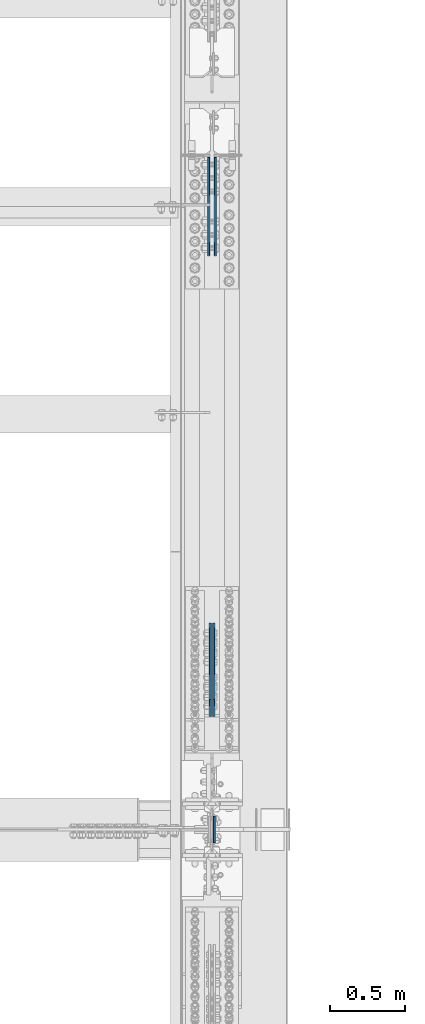
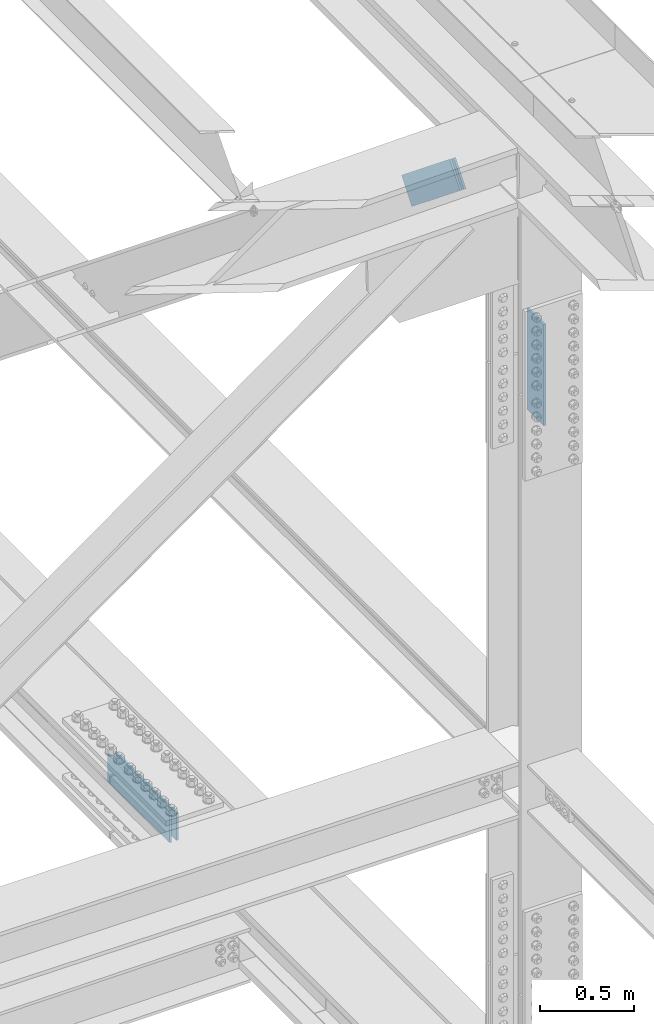
# One storey, part 2684 of 3843: 3 beams, 2 members, 2 elements without a shape of their own.
"""IFC2X3 building model written with IfcOpenShell, lengths in millimetres."""

from ifc_helpers import new_model, si_unit, frame, origin_with_axes, place, context, subcontext, project, spatial, faceted_brep, material, type_object, element, aggregate, save


model = new_model("IFC2X3")

# Units and contexts
model_context = context("Model", 3, precision=1e-05, world=origin_with_axes())
body_context = subcontext(model_context, "Body", "Model", "MODEL_VIEW")
ifc_project = project(units=[si_unit("LENGTHUNIT", "METRE", prefix="MILLI"), si_unit("AREAUNIT", "SQUARE_METRE"), si_unit("VOLUMEUNIT", "CUBIC_METRE"), si_unit("MASSUNIT", "GRAM", prefix="KILO"), si_unit("TIMEUNIT", "SECOND"), si_unit("PLANEANGLEUNIT", "RADIAN"), si_unit("SOLIDANGLEUNIT", "STERADIAN"), si_unit("THERMODYNAMICTEMPERATUREUNIT", "DEGREE_CELSIUS"), si_unit("LUMINOUSINTENSITYUNIT", "LUMEN")], contexts=[model_context])

# Site, building, storey
site_placement = place(None, origin_with_axes())
site = spatial("IfcSite", under=ifc_project, at=site_placement, CompositionType="ELEMENT")
building_placement = place(site_placement, origin_with_axes())
building = spatial("IfcBuilding", under=site, at=building_placement, Name="Undefined", CompositionType="ELEMENT")
storey_placement = place(building_placement, origin_with_axes())
storey = spatial("IfcBuildingStorey", under=building, at=storey_placement, Name="Undefined", CompositionType="ELEMENT", Elevation=0.0)

# Assembly, beam
assembly_1_placement = place(storey_placement, origin_with_axes())
assembly_1 = element("IfcElementAssembly", 1, at=assembly_1_placement, inside=storey, Name="BEAM", AssemblyPlace="NOTDEFINED", PredefinedType="RIGID_FRAME")
ifc_material = material(Name="STEEL/A572-50")
beam_type = type_object("IfcBeamType", PredefinedType="NOTDEFINED")
beam_1_placement = place(assembly_1_placement, frame((85663.0875, 42202.0999999926, 45204.5156721454), z_axis=(0.0, 1.0, 0.0), x_axis=(0.0, 0.0, -1.0)))
beam_1 = element("IfcBeam", 2, at=beam_1_placement, type_object=beam_type, material=ifc_material, Name="PLATE", context=body_context, shape_type="Brep", body=[
    faceted_brep([(1.45519152283669e-11, 6.35000000000582, -88.8999999998996), (0.0, 6.34999999999854, 88.9000015258789), (660.399999982677, 6.35000000000582, 88.8999999999651), (660.399999982707, 6.35000000000582, -88.8999999998268), (0.0, -6.34999999999854, 88.9000015258789), (660.399999982677, -6.35000000000582, 88.8999999999651), (1.45519152283669e-11, -6.35000000000582, -88.8999999998996), (660.399999982707, -6.35000000000582, -88.8999999998268)], [[[0, 1, 2, 3]], [[1, 4, 5, 2]], [[4, 6, 7, 5]], [[6, 0, 3, 7]], [[5, 7, 3, 2]], [[6, 4, 1, 0]]]),
])

# Assembly, beams
assembly_2_placement = place(storey_placement, origin_with_axes())
assembly_2 = element("IfcElementAssembly", 3, at=assembly_2_placement, inside=storey, Name="BEAM", AssemblyPlace="NOTDEFINED", PredefinedType="RIGID_FRAME")
beam_2_placement = place(assembly_2_placement, frame((85627.36875, 46711.0348412401, 39540.1325263648), z_axis=(0.0, 0.00209441799938213, -0.999997806704217), x_axis=(0.0, -0.999997806704217, -0.00209441799938414)))
beam_2 = element("IfcBeam", 4, at=beam_2_placement, type_object=beam_type, material=ifc_material, Name="PLATE", context=body_context, shape_type="Brep", body=[
    faceted_brep([(1.45519152283669e-11, 6.35000000000582, -88.8999999998996), (0.0, 6.34999999999854, 88.9000015258789), (660.399999982677, 6.35000000000582, 88.8999999999651), (660.399999982707, 6.35000000000582, -88.8999999998268), (0.0, -6.34999999999854, 88.9000015258789), (660.399999982677, -6.35000000000582, 88.8999999999651), (1.45519152283669e-11, -6.35000000000582, -88.8999999998996), (660.399999982707, -6.35000000000582, -88.8999999998268)], [[[0, 1, 2, 3]], [[1, 4, 5, 2]], [[4, 6, 7, 5]], [[6, 0, 3, 7]], [[5, 7, 3, 2]], [[6, 4, 1, 0]]]),
])
beam_3_placement = place(assembly_2_placement, frame((85670.23125, 46711.0348412401, 39540.1325263648), z_axis=(0.0, 0.00209441799938213, -0.999997806704217), x_axis=(0.0, -0.999997806704217, -0.00209441799938414)))
beam_3 = element("IfcBeam", 5, at=beam_3_placement, type_object=beam_type, material=ifc_material, Name="PLATE", context=body_context, shape_type="Brep", body=[
    faceted_brep([(1.45519152283669e-11, 6.35000000000582, -88.8999999998996), (0.0, 6.34999999999854, 88.9000015258789), (660.399999982677, 6.35000000000582, 88.8999999999651), (660.399999982707, 6.35000000000582, -88.8999999998268), (0.0, -6.34999999999854, 88.9000015258789), (660.399999982677, -6.35000000000582, 88.8999999999651), (1.45519152283669e-11, -6.35000000000582, -88.8999999998996), (660.399999982707, -6.35000000000582, -88.8999999998268)], [[[0, 1, 2, 3]], [[1, 4, 5, 2]], [[4, 6, 7, 5]], [[6, 0, 3, 7]], [[5, 7, 3, 2]], [[6, 4, 1, 0]]]),
])
aggregate(assembly_2, [beam_2, beam_3])

# Member
member_type = type_object("IfcMemberType", PredefinedType="NOTDEFINED")
member_1_placement = place(assembly_1_placement, frame((85636.1, 43017.788602309, 45642.1172586876), z_axis=(0.0, 0.628634438193607, 0.777700934239511), x_axis=(0.0, 0.777700934239514, -0.628634438193604)))
member_1 = element("IfcMember", 6, at=member_1_placement, type_object=member_type, material=ifc_material, Name="PLATE", context=body_context, shape_type="Brep", body=[
    faceted_brep([(1.45519152283669e-11, 6.35000000000582, -88.8999999998996), (0.0, 6.34999999999854, 88.9000015258789), (660.399999982677, 6.35000000000582, 88.8999999999651), (660.399999982707, 6.35000000000582, -88.8999999998268), (0.0, -6.34999999999854, 88.9000015258789), (660.399999982677, -6.35000000000582, 88.8999999999651), (1.45519152283669e-11, -6.35000000000582, -88.8999999998996), (660.399999982707, -6.35000000000582, -88.8999999998268)], [[[0, 1, 2, 3]], [[1, 4, 5, 2]], [[4, 6, 7, 5]], [[6, 0, 3, 7]], [[5, 7, 3, 2]], [[6, 4, 1, 0]]]),
])

member_2_placement = place(assembly_1_placement, frame((85661.5, 43017.788602309, 45642.1172586876), z_axis=(0.0, 0.628634438193607, 0.777700934239511), x_axis=(0.0, 0.777700934239514, -0.628634438193604)))
member_2 = element("IfcMember", 7, at=member_2_placement, type_object=member_type, material=ifc_material, Name="PLATE", context=body_context, shape_type="Brep", body=[
    faceted_brep([(1.45519152283669e-11, 6.35000000000582, -88.8999999998996), (0.0, 6.34999999999854, 88.9000015258789), (660.399999982677, 6.35000000000582, 88.8999999999651), (660.399999982707, 6.35000000000582, -88.8999999998268), (0.0, -6.34999999999854, 88.9000015258789), (660.399999982677, -6.35000000000582, 88.8999999999651), (1.45519152283669e-11, -6.35000000000582, -88.8999999998996), (660.399999982707, -6.35000000000582, -88.8999999998268)], [[[0, 1, 2, 3]], [[1, 4, 5, 2]], [[4, 6, 7, 5]], [[6, 0, 3, 7]], [[5, 7, 3, 2]], [[6, 4, 1, 0]]]),
])

aggregate(assembly_1, [member_1, member_2, beam_1])

save(model, "model.ifc")
